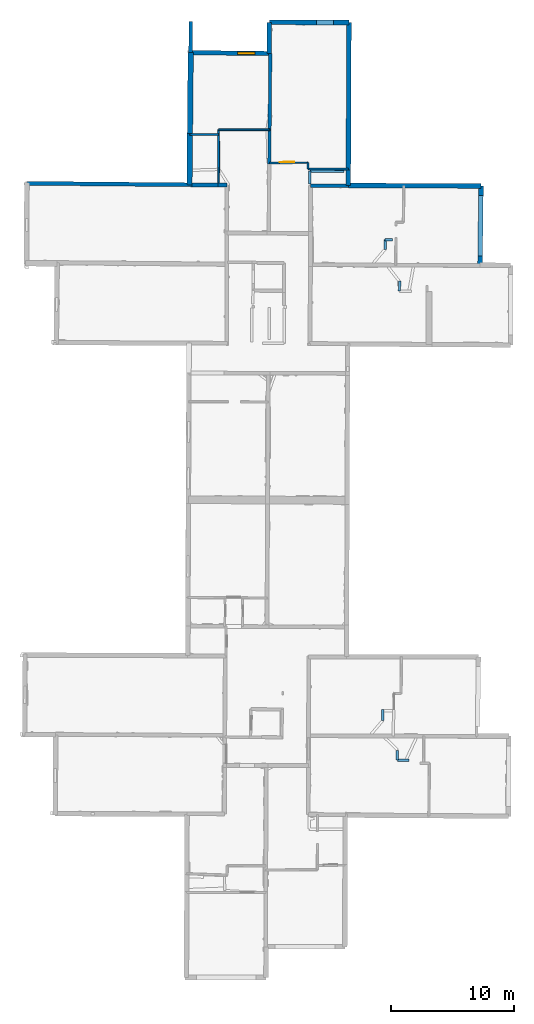
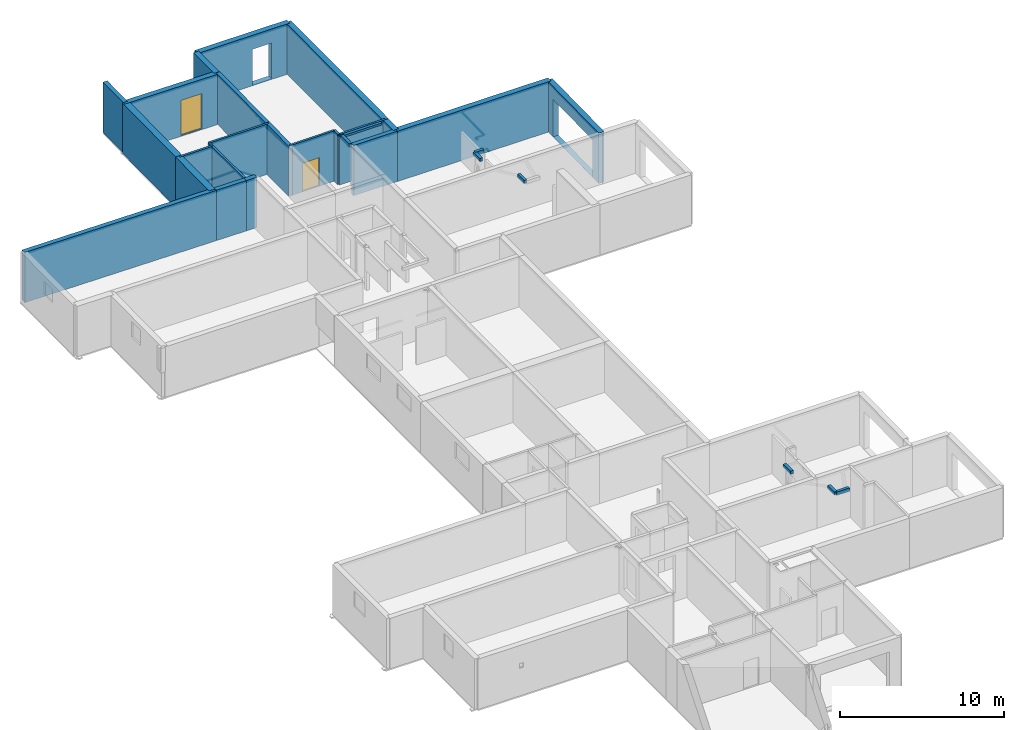
# One storey, part 7 of 12: 30 walls, 1 door, 1 window, 4 openings.
"""IFC2X3 building model written with IfcOpenShell, lengths in metres."""

from ifc_helpers import new_model, entity, si_unit, converted_unit, derived_unit, direction, frame, frame_2d, origin, origin_2d_with_axis, place, context, subcontext, project, spatial, polyline, rectangle, outline, extrude, source, transform, mapped, material, layer, layer_set, layer_usage, type_object, type_shapes, element, fill, save


model = new_model("IFC2X3")

# Units and contexts
model_context = context("Model", 3, precision=1e-05, world=origin(), true_north=direction((0.0, 1.0)))
body_context = subcontext(model_context, "Body", "Model", "MODEL_VIEW")
ifc_project = project(units=[si_unit("LENGTHUNIT", "METRE"), si_unit("AREAUNIT", "SQUARE_METRE"), si_unit("VOLUMEUNIT", "CUBIC_METRE"), converted_unit("PLANEANGLEUNIT", "DEGREE", entity("IfcRatioMeasure", 0.0174532925199433), si_unit("PLANEANGLEUNIT", "RADIAN"), dimensions=[0, 0, 0, 0, 0, 0, 0]), si_unit("MASSUNIT", "GRAM", prefix="KILO"), derived_unit("MASSDENSITYUNIT", [(si_unit("MASSUNIT", "GRAM", prefix="KILO"), 1), (si_unit("LENGTHUNIT", "METRE"), -3)]), derived_unit("MOMENTOFINERTIAUNIT", [(si_unit("LENGTHUNIT", "METRE"), 4)]), si_unit("TIMEUNIT", "SECOND"), si_unit("FREQUENCYUNIT", "HERTZ"), si_unit("THERMODYNAMICTEMPERATUREUNIT", "DEGREE_CELSIUS"), derived_unit("THERMALTRANSMITTANCEUNIT", [(si_unit("MASSUNIT", "GRAM", prefix="KILO"), 1), (si_unit("THERMODYNAMICTEMPERATUREUNIT", "KELVIN"), -1), (si_unit("TIMEUNIT", "SECOND"), -3)]), derived_unit("VOLUMETRICFLOWRATEUNIT", [(si_unit("LENGTHUNIT", "METRE"), 3), (si_unit("TIMEUNIT", "SECOND"), -1)]), si_unit("ELECTRICCURRENTUNIT", "AMPERE"), si_unit("ELECTRICVOLTAGEUNIT", "VOLT"), si_unit("POWERUNIT", "WATT"), si_unit("FORCEUNIT", "NEWTON", prefix="KILO"), si_unit("ILLUMINANCEUNIT", "LUX"), si_unit("LUMINOUSFLUXUNIT", "LUMEN"), si_unit("LUMINOUSINTENSITYUNIT", "CANDELA"), derived_unit("USERDEFINED", [(si_unit("MASSUNIT", "GRAM", prefix="KILO"), -1), (si_unit("LENGTHUNIT", "METRE"), -2), (si_unit("TIMEUNIT", "SECOND"), 3), (si_unit("LUMINOUSFLUXUNIT", "LUMEN"), 1)]), derived_unit("LINEARVELOCITYUNIT", [(si_unit("LENGTHUNIT", "METRE"), 1), (si_unit("TIMEUNIT", "SECOND"), -1)]), si_unit("PRESSUREUNIT", "PASCAL"), derived_unit("USERDEFINED", [(si_unit("LENGTHUNIT", "METRE"), -2), (si_unit("MASSUNIT", "GRAM", prefix="KILO"), 1), (si_unit("TIMEUNIT", "SECOND"), -2)]), derived_unit("LINEARFORCEUNIT", [(si_unit("MASSUNIT", "GRAM", prefix="KILO"), 1), (si_unit("LENGTHUNIT", "METRE"), 1), (si_unit("TIMEUNIT", "SECOND"), -2), (si_unit("LENGTHUNIT", "METRE"), -1)]), derived_unit("PLANARFORCEUNIT", [(si_unit("MASSUNIT", "GRAM", prefix="KILO"), 1), (si_unit("LENGTHUNIT", "METRE"), 1), (si_unit("TIMEUNIT", "SECOND"), -2), (si_unit("LENGTHUNIT", "METRE"), -2)])], contexts=[model_context])

# Site, building, storey
placement_1 = place(None, origin())
site = spatial("IfcSite", under=ifc_project, at=placement_1, CompositionType="ELEMENT")
building = spatial("IfcBuilding", under=site, at=placement_1, CompositionType="ELEMENT")
storey_placement = place(placement_1, frame((0.0, 0.0, -1.46125340461731)))
storey = spatial("IfcBuildingStorey", under=building, at=storey_placement, Name="Level 1", CompositionType="ELEMENT", Elevation=-1.46125340461731)

# Walls
ifc_material_1 = material(Name="Default wall")
ifc_layer_1 = layer(ifc_material_1, 0.2)
ifc_layer_set_1 = layer_set([ifc_layer_1], Name="wall_thickness_0.2000")
ifc_layer_usage_1 = layer_usage(ifc_layer_set_1, "AXIS2", "POSITIVE", -0.1)
wall_type_1 = type_object("IfcWallType", Name="wall_thickness_0.2000", PredefinedType="STANDARD", material=ifc_layer_set_1)
placement_2 = place(placement_1, frame((0.0, 0.0, 2.04199981689453)))
wall_1_placement = place(placement_2, frame((16.985654750279, 56.2841287102002, 0.0), z_axis=(0.0, 0.0, 1.0), x_axis=(-0.0121053675292817, -0.99992672735405, 0.0)))
element("IfcWallStandardCase", 1, at=wall_1_placement, inside=storey, type_object=wall_type_1, material=ifc_layer_usage_1, Name="Wall:504", ObjectType="Wall", context=body_context, shape_type="SweptSolid", body=[
    extrude(outline(polyline([(0.816172321416088, -0.1), (0.816172321416088, 0.1), (0.0, 0.1), (0.0, -0.1), (0.816172321416088, -0.1)])), origin(), (0.0, 0.0, 1.0), 0.238732957839966),
])
placement_3 = place(placement_1, frame((0.0, 0.0, 2.04199981689453)))
wall_2_placement = place(placement_3, frame((16.8142261509141, 17.420475651586, 0.0), z_axis=(0.0, 0.0, 1.0), x_axis=(0.999991195936231, -0.00419619470792084, 0.0)))
element("IfcWallStandardCase", 2, at=wall_2_placement, inside=storey, type_object=wall_type_1, material=ifc_layer_usage_1, Name="Wall:505", ObjectType="Wall", context=body_context, shape_type="SweptSolid", body=[
    extrude(outline(polyline([(0.923630263047391, -0.1), (0.923630263047391, 0.1), (0.0, 0.1), (0.0, -0.1), (0.923630263047391, -0.1)])), origin(), (0.0, 0.0, 1.0), 0.238732957839966),
])
placement_4 = place(placement_1, frame((0.0, 0.0, 2.04199981689453)))
wall_3_placement = place(placement_4, frame((9.69834329614424, 64.1648029776618, 0.0), z_axis=(0.0, 0.0, 1.0), x_axis=(0.00701452156473721, 0.999975397940978, 0.0)))
element("IfcWallStandardCase", 3, at=wall_3_placement, inside=storey, type_object=wall_type_1, material=ifc_layer_usage_1, Name="Wall:583", ObjectType="Wall", context=body_context, shape_type="SweptSolid", body=[
    extrude(outline(polyline([(1.04156767793214, -0.1), (1.04156767793214, 0.1), (0.0, 0.1), (0.0, -0.1), (1.04156767793214, -0.1)])), origin(), (0.0, 0.0, 1.0), 0.238732957839966),
])
placement_5 = place(placement_1, frame((0.0, 0.0, 2.04199981689453)))
wall_4_placement = place(placement_5, frame((16.808737898838, 18.2231718518837, 0.0), z_axis=(0.0, 0.0, 1.0), x_axis=(0.00683613511522928, -0.999976633355343, 0.0)))
element("IfcWallStandardCase", 4, at=wall_4_placement, inside=storey, type_object=wall_type_1, material=ifc_layer_usage_1, Name="Wall:611", ObjectType="Wall", context=body_context, shape_type="SweptSolid", body=[
    extrude(outline(polyline([(0.80271116999675, -0.1), (0.80271116999675, 0.1), (0.0, 0.1), (0.0, -0.1), (0.80271116999675, -0.1)])), origin(), (0.0, 0.0, 1.0), 0.238732957839966),
])
placement_6 = place(placement_1, frame((0.0, 0.0, 2.12299990653992)))
wall_5_placement = place(placement_6, frame((9.70564890685187, 65.2063443058556, 0.0), z_axis=(0.0, 0.0, 1.0), x_axis=(0.999987730149412, -0.00495374107381496, 0.0)))
element("IfcWallStandardCase", 5, at=wall_5_placement, inside=storey, type_object=wall_type_1, material=ifc_layer_usage_1, Name="Wall:655", ObjectType="Wall", context=body_context, shape_type="SweptSolid", body=[
    extrude(outline(polyline([(2.75836895830037, -0.1), (2.75836895830037, 0.1), (0.0, 0.1), (0.0, -0.1), (2.75836895830037, -0.1)])), origin(), (0.0, 0.0, 1.0), 0.15773286819458),
])
placement_7 = place(placement_1, frame((0.0, 0.0, 2.04199981689453)))
wall_6_placement = place(placement_7, frame((15.8125416978923, 59.6423287890546, 0.0), z_axis=(0.0, 0.0, 1.0), x_axis=(0.999998553805146, 0.00170070209538718, 0.0)))
element("IfcWallStandardCase", 6, at=wall_6_placement, inside=storey, type_object=wall_type_1, material=ifc_layer_usage_1, Name="Wall:676", ObjectType="Wall", context=body_context, shape_type="SweptSolid", body=[
    extrude(outline(polyline([(0.601127540184958, -0.1), (0.601127540184958, 0.1), (0.0, 0.1), (0.0, -0.1), (0.601127540184958, -0.1)])), origin(), (0.0, 0.0, 1.0), 0.238732957839966),
])
placement_8 = place(placement_1, frame((0.0, 0.0, 2.04199981689453)))
wall_7_placement = place(placement_8, frame((15.6015710128268, 21.5458410889888, 0.0), z_axis=(0.0, 0.0, 1.0), x_axis=(0.00358453481528218, -0.999993575534442, 0.0)))
element("IfcWallStandardCase", 7, at=wall_7_placement, inside=storey, type_object=wall_type_1, material=ifc_layer_usage_1, Name="Wall:682", ObjectType="Wall", context=body_context, shape_type="SweptSolid", body=[
    extrude(outline(polyline([(0.895000485617568, -0.1), (0.895000485617568, 0.1), (0.0, 0.1), (0.0, -0.1), (0.895000485617568, -0.1)])), origin(), (0.0, 0.0, 1.0), 0.238732957839966),
])
placement_9 = place(placement_1, frame((0.0, 0.0, 2.04199981689453)))
wall_8_placement = place(placement_9, frame((15.8125424604452, 59.6423196106823, 0.0), z_axis=(0.0, 0.0, 1.0), x_axis=(-0.00121170724026811, -0.999999265882512, 0.0)))
element("IfcWallStandardCase", 8, at=wall_8_placement, inside=storey, type_object=wall_type_1, material=ifc_layer_usage_1, Name="Wall:683", ObjectType="Wall", context=body_context, shape_type="SweptSolid", body=[
    extrude(outline(polyline([(0.805939312357268, -0.1), (0.805939312357268, 0.1), (0.0, 0.1), (0.0, -0.1), (0.805939312357268, -0.1)])), origin(), (0.0, 0.0, 1.0), 0.238732957839966),
])
ifc_layer_2 = layer(ifc_material_1, 0.259999990463257)
ifc_layer_set_2 = layer_set([ifc_layer_2], Name="wall_thickness_0.2600")
ifc_layer_usage_2 = layer_usage(ifc_layer_set_2, "AXIS2", "POSITIVE", -0.129999995231628)
wall_type_2 = type_object("IfcWallType", Name="wall_thickness_0.2600", PredefinedType="STANDARD", material=ifc_layer_set_2)
wall_9_placement = place(storey_placement, frame((6.49996284418517, 74.7443415367657, 0.0), z_axis=(0.0, 0.0, 1.0), x_axis=(-0.00925311069373297, -0.999957189054856, 0.0)))
element("IfcWallStandardCase", 9, at=wall_9_placement, inside=storey, type_object=wall_type_2, material=ifc_layer_usage_2, Name="Wall:622", ObjectType="Wall", context=body_context, shape_type="SweptSolid", body=[
    extrude(outline(polyline([(6.10981204290243, -0.129999995231628), (6.10981204290243, 0.129999995231628), (0.0, 0.129999995231628), (0.0, -0.129999995231628), (6.10981204290243, -0.129999995231628)])), origin(), (0.0, 0.0, 1.0), 3.74198617935181),
])
wall_10_placement = place(storey_placement, frame((6.44342807703429, 68.6347910606915, 0.0), z_axis=(0.0, 0.0, 1.0), x_axis=(-0.00925297889568867, -0.999957190274442, 0.0)))
element("IfcWallStandardCase", 10, at=wall_10_placement, inside=storey, type_object=wall_type_2, material=ifc_layer_usage_2, Name="Wall:623", ObjectType="Wall", context=body_context, shape_type="SweptSolid", body=[
    extrude(outline(polyline([(2.84840379973651, -0.129999995231628), (2.84840379973651, 0.129999995231628), (0.0, 0.129999995231628), (0.0, -0.129999995231628), (2.84840379973651, -0.129999995231628)])), origin(), (0.0, 0.0, 1.0), 3.74198617935181),
])
ifc_layer_3 = layer(ifc_material_1, 0.379999995231628)
ifc_layer_set_3 = layer_set([ifc_layer_3], Name="wall_thickness_0.3800")
ifc_layer_usage_3 = layer_usage(ifc_layer_set_3, "AXIS2", "POSITIVE", -0.189999997615814)
wall_type_3 = type_object("IfcWallType", Name="wall_thickness_0.3800", PredefinedType="STANDARD", material=ifc_layer_set_3)
wall_11_placement = place(storey_placement, frame((12.8271769752851, 64.0465283454255, 0.0), z_axis=(0.0, 0.0, 1.0), x_axis=(0.999990247252892, -0.0044164917185579, 0.0)))
element("IfcWallStandardCase", 11, at=wall_11_placement, inside=storey, type_object=wall_type_3, material=ifc_layer_usage_3, Name="Wall:577", ObjectType="Wall", context=body_context, shape_type="SweptSolid", body=[
    extrude(outline(polyline([(10.7656460712837, -0.189999997615814), (10.7656460712837, 0.189999997615814), (0.0, 0.189999997615814), (0.0, -0.189999997615814), (10.7656460712837, -0.189999997615814)])), origin(), (0.0, 0.0, 1.0), 3.74198617935181),
])

# Wall, opening
wall_12_placement = place(storey_placement, frame((6.42383307155813, 77.275378400751, 0.0), z_axis=(0.0, 0.0, 1.0), x_axis=(0.999996892159808, -0.00249312469098488, 0.0)))
wall_12 = element("IfcWallStandardCase", 12, at=wall_12_placement, inside=storey, type_object=wall_type_3, material=ifc_layer_usage_3, Name="Wall:607", ObjectType="Wall", context=body_context, shape_type="SweptSolid", body=[
    extrude(outline(polyline([(6.45696644020566, -0.189999997615814), (6.45696644020566, 0.189999997615814), (0.0, 0.189999997615814), (0.0, -0.189999997615814), (6.45696644020566, -0.189999997615814)])), origin(), (0.0, 0.0, 1.0), 3.74198617935181),
])
opening_1_placement = place(wall_12_placement, frame((3.83814585930286, -0.189999997615814, 0.0252540111541748)))
element("IfcOpeningElement", 13, at=opening_1_placement, cuts=wall_12, Name="Opening : 1345 x 2675 : 420", ObjectType="Opening", context=body_context, shape_type="SweptSolid", body=[
    extrude(rectangle(XDim=1.345, YDim=2.675, at=frame_2d((1.3375, 0.6725), x_axis=(0.0, 1.0))), frame((0.0, 0.0, 0.0), z_axis=(0.0, 1.0, 0.0), x_axis=(0.0, 0.0, 1.0)), (0.0, 0.0, 1.0), 0.379999995231628),
])

# Walls
wall_13_placement = place(storey_placement, frame((12.8807794590913, 77.2592776062909, 0.0), z_axis=(0.0, 0.0, 1.0), x_axis=(-0.00405701268422261, -0.999991770290176, 0.0)))
element("IfcWallStandardCase", 14, at=wall_13_placement, inside=storey, type_object=wall_type_3, material=ifc_layer_usage_3, Name="Wall:645", ObjectType="Wall", context=body_context, shape_type="SweptSolid", body=[
    extrude(outline(polyline([(11.9640266831242, -0.189999997615814), (11.9640266831242, 0.189999997615814), (0.0, 0.189999997615814), (0.0, -0.189999997615814), (11.9640266831242, -0.189999997615814)])), origin(), (0.0, 0.0, 1.0), 3.74198617935181),
])
wall_14_placement = place(storey_placement, frame((12.8322412510835, 65.2953493836346, 0.0), z_axis=(0.0, 0.0, 1.0), x_axis=(-0.00405735191516471, -0.999991768913843, 0.0)))
element("IfcWallStandardCase", 15, at=wall_14_placement, inside=storey, type_object=wall_type_3, material=ifc_layer_usage_3, Name="Wall:646", ObjectType="Wall", context=body_context, shape_type="SweptSolid", body=[
    extrude(outline(polyline([(1.24881246414158, -0.189999997615814), (1.24881246414158, 0.189999997615814), (0.0, 0.189999997615814), (0.0, -0.189999997615814), (1.24881246414158, -0.189999997615814)])), origin(), (0.0, 0.0, 1.0), 3.74198617935181),
])

# Wall, opening
wall_15_placement = place(storey_placement, frame((23.5927183697657, 63.9989821402971, 0.0), z_axis=(0.0, 0.0, 1.0), x_axis=(-0.0125521284656519, -0.999921218932263, 0.0)))
wall_15 = element("IfcWallStandardCase", 16, at=wall_15_placement, inside=storey, type_object=wall_type_3, material=ifc_layer_usage_3, Name="Wall:647", ObjectType="Wall", context=body_context, shape_type="SweptSolid", body=[
    extrude(outline(polyline([(6.45410266886321, -0.189999997615814), (6.45410266886321, 0.189999997615814), (0.0, 0.189999997615814), (0.0, -0.189999997615814), (6.45410266886321, -0.189999997615814)])), origin(), (0.0, 0.0, 1.0), 3.74198617935181),
])
opening_2_placement = place(wall_15_placement, frame((0.781940975481089, -0.189999997615814, 0.00525403022766113)))
element("IfcOpeningElement", 17, at=opening_2_placement, cuts=wall_15, Name="Opening : 4910 x 2770 : 424", ObjectType="Opening", context=body_context, shape_type="SweptSolid", body=[
    extrude(rectangle(XDim=4.91, YDim=2.77, at=frame_2d((1.385, 2.455), x_axis=(0.0, 1.0))), frame((0.0, 0.0, 0.0), z_axis=(0.0, 1.0, 0.0), x_axis=(0.0, 0.0, 1.0)), (0.0, 0.0, 1.0), 0.379999995231628),
])

# Wall
ifc_layer_4 = layer(ifc_material_1, 0.370000004768372)
ifc_layer_set_4 = layer_set([ifc_layer_4], Name="wall_thickness_0.3700")
ifc_layer_usage_4 = layer_usage(ifc_layer_set_4, "AXIS2", "POSITIVE", -0.185000002384186)
wall_type_4 = type_object("IfcWallType", Name="wall_thickness_0.3700", PredefinedType="STANDARD", material=ifc_layer_set_4)
wall_16_placement = place(storey_placement, frame((6.4238338680527, 77.2753813323718, 0.0), z_axis=(0.0, 0.0, 1.0), x_axis=(-0.00458695900539811, -0.999989479848205, 0.0)))
element("IfcWallStandardCase", 18, at=wall_16_placement, inside=storey, type_object=wall_type_4, material=ifc_layer_usage_4, Name="Wall:517", ObjectType="Wall", context=body_context, shape_type="SweptSolid", body=[
    extrude(outline(polyline([(2.53005591344726, -0.185000002384186), (2.53005591344726, 0.185000002384186), (0.0, 0.185000002384186), (0.0, -0.185000002384186), (2.53005591344726, -0.185000002384186)])), origin(), (0.0, 0.0, 1.0), 3.74198617935181),
])

# Wall, opening, window
ifc_layer_5 = layer(ifc_material_1, 0.360000014305115)
ifc_layer_set_5 = layer_set([ifc_layer_5], Name="wall_thickness_0.3600")
ifc_layer_usage_5 = layer_usage(ifc_layer_set_5, "AXIS2", "POSITIVE", -0.180000007152557)
wall_type_5 = type_object("IfcWallType", Name="wall_thickness_0.3600", PredefinedType="STANDARD", material=ifc_layer_set_5)
wall_17_placement = place(storey_placement, frame((-0.0998049657116847, 74.8212939685536, 0.0), z_axis=(0.0, 0.0, 1.0), x_axis=(0.999932034790129, -0.0116587220771741, 0.0)))
wall_17 = element("IfcWallStandardCase", 19, at=wall_17_placement, inside=storey, type_object=wall_type_5, material=ifc_layer_usage_5, Name="Wall:572", ObjectType="Wall", context=body_context, shape_type="SweptSolid", body=[
    extrude(outline(polyline([(6.60021507784659, -0.180000007152557), (6.60021507784659, 0.180000007152557), (0.0, 0.180000007152557), (0.0, -0.180000007152557), (6.60021507784659, -0.180000007152557)])), origin(), (0.0, 0.0, 1.0), 3.74198617935181),
])
opening_3_placement = place(wall_17_placement, frame((3.91921047289283, -0.180000007152557, 0.0702539682388306)))
opening_3 = element("IfcOpeningElement", 20, at=opening_3_placement, cuts=wall_17, Name="Opening : 1440 x 2610 : 413", ObjectType="Opening", context=body_context, shape_type="SweptSolid", body=[
    extrude(rectangle(XDim=1.44, YDim=2.61, at=frame_2d((1.305, 0.72), x_axis=(0.0, 1.0))), frame((0.0, 0.0, 0.0), z_axis=(0.0, 1.0, 0.0), x_axis=(0.0, 0.0, 1.0)), (0.0, 0.0, 1.0), 0.360000014305115),
])
ifc_material_2 = material(Name="Window Default")
window_style = type_object("IfcWindowStyle", Name="Window : 1440 x 2610mm", ConstructionType="NOTDEFINED", OperationType="NOTDEFINED", ParameterTakesPrecedence=False, Sizeable=False, material=ifc_material_2)
shared_shape_1 = source(origin(), body_context, "Body", "SweptSolid", [
    extrude(rectangle(XDim=0.180000007152557, YDim=1.44, at=origin_2d_with_axis()), frame((0.72, 0.180000007152557, 0.0), z_axis=(0.0, 0.0, 1.0), x_axis=(0.0, 1.0, 0.0)), (0.0, 0.0, 1.0), 2.61),
])
type_shapes(window_style, [shared_shape_1])
window_placement = place(opening_3_placement, origin())
window = element("IfcWindow", 21, at=window_placement, inside=storey, type_object=window_style, Name="Window : 1440 x 2610mm : 229", ObjectType="Window : 1440 x 2610mm", OverallHeight=2.61, OverallWidth=1.44, context=body_context, shape_type="MappedRepresentation", body=[
    mapped(shared_shape_1, transform((0.0, 0.0, 0.0), scale=1.0)),
])
fill(opening_3, window)

# Walls
ifc_layer_6 = layer(ifc_material_1, 0.150000005960464)
ifc_layer_set_6 = layer_set([ifc_layer_6], Name="wall_thickness_0.1500")
ifc_layer_usage_6 = layer_usage(ifc_layer_set_6, "AXIS2", "POSITIVE", -0.0750000029802322)
wall_type_6 = type_object("IfcWallType", Name="wall_thickness_0.1500", PredefinedType="STANDARD", material=ifc_layer_set_6)
wall_18_placement = place(storey_placement, frame((9.57041502275993, 65.3777647023615, 0.0), z_axis=(0.0, 0.0, 1.0), x_axis=(0.999997416086211, -0.00227328416665952, 0.0)))
element("IfcWallStandardCase", 22, at=wall_18_placement, inside=storey, type_object=wall_type_6, material=ifc_layer_usage_6, Name="Wall:536", ObjectType="Wall", context=body_context, shape_type="SweptSolid", body=[
    extrude(outline(polyline([(3.26214012006784, -0.0750000029802322), (3.26214012006784, 0.0750000029802322), (0.0, 0.0750000029802322), (0.0, -0.0750000029802322), (3.26214012006784, -0.0750000029802322)])), origin(), (0.0, 0.0, 1.0), 3.74198617935181),
])
wall_19_placement = place(storey_placement, frame((2.29924030453117, 68.5605285626273, 0.0), z_axis=(0.0, 0.0, 1.0), x_axis=(0.99999998437719, -0.000176764305854658, 0.0)))
element("IfcWallStandardCase", 23, at=wall_19_placement, inside=storey, type_object=wall_type_6, material=ifc_layer_usage_6, Name="Wall:568", ObjectType="Wall", context=body_context, shape_type="SweptSolid", body=[
    extrude(outline(polyline([(4.14349419391393, -0.0750000029802322), (4.14349419391393, 0.0750000029802322), (0.0, 0.0750000029802322), (0.0, -0.0750000029802322), (4.14349419391393, -0.0750000029802322)])), origin(), (0.0, 0.0, 1.0), 3.74198617935181),
])

# Wall, opening, door
wall_20_placement = place(storey_placement, frame((6.41776554010795, 65.8614954213008, 0.0), z_axis=(0.0, 0.0, 1.0), x_axis=(0.999951938311909, 0.00980413516103042, 0.0)))
wall_20 = element("IfcWallStandardCase", 24, at=wall_20_placement, inside=storey, type_object=wall_type_6, material=ifc_layer_usage_6, Name="Wall:596", ObjectType="Wall", context=body_context, shape_type="SweptSolid", body=[
    extrude(outline(polyline([(3.15396876188173, -0.0750000029802322), (3.15396876188173, 0.0750000029802322), (0.0, 0.0750000029802322), (0.0, -0.0750000029802322), (3.15396876188173, -0.0750000029802322)])), origin(), (0.0, 0.0, 1.0), 3.74198617935181),
])
opening_4_placement = place(wall_20_placement, frame((0.841534071344861, -0.0750000029802322, 0.00525403022766113)))
opening_4 = element("IfcOpeningElement", 25, at=opening_4_placement, cuts=wall_20, Name="Opening : 1195 x 2120 : 418", ObjectType="Opening", context=body_context, shape_type="SweptSolid", body=[
    extrude(rectangle(XDim=1.195, YDim=2.12, at=frame_2d((1.06, 0.5975), x_axis=(0.0, 1.0))), frame((0.0, 0.0, 0.0), z_axis=(0.0, 1.0, 0.0), x_axis=(0.0, 0.0, 1.0)), (0.0, 0.0, 1.0), 0.150000005960464),
])
ifc_material_3 = material(Name="Door Panel")
door_style = type_object("IfcDoorStyle", Name="Door : 1195 x 2120mm", ConstructionType="NOTDEFINED", OperationType="SINGLE_SWING_RIGHT", ParameterTakesPrecedence=False, Sizeable=False, material=ifc_material_3)
shared_shape_2 = source(origin(), body_context, "Body", "SweptSolid", [
    extrude(rectangle(XDim=0.0375000014901161, YDim=1.195, at=origin_2d_with_axis()), frame((0.5975, 0.131250005215406, 0.0), z_axis=(0.0, 0.0, 1.0), x_axis=(0.0, 1.0, 0.0)), (0.0, 0.0, 1.0), 2.12),
])
type_shapes(door_style, [shared_shape_2])
door_placement = place(opening_4_placement, origin())
door = element("IfcDoor", 26, at=door_placement, inside=storey, type_object=door_style, Name="Door : 1195 x 2120mm : 78", ObjectType="Door : 1195 x 2120mm", OverallHeight=2.12, OverallWidth=1.195, context=body_context, shape_type="MappedRepresentation", body=[
    mapped(shared_shape_2, transform((0.0, 0.0, 0.0), scale=1.0)),
])
fill(opening_4, door)

# Walls
wall_21_placement = place(storey_placement, frame((-0.0197053436772811, 68.1802567292397, 0.0), z_axis=(0.0, 0.0, 1.0), x_axis=(0.999998943990349, -0.00145327842746965, 0.0)))
element("IfcWallStandardCase", 27, at=wall_21_placement, inside=storey, type_object=wall_type_6, material=ifc_layer_usage_6, Name="Wall:600", ObjectType="Wall", context=body_context, shape_type="SweptSolid", body=[
    extrude(outline(polyline([(2.32040352287065, -0.0750000029802322), (2.32040352287065, 0.0750000029802322), (0.0, 0.0750000029802322), (0.0, -0.0750000029802322), (2.32040352287065, -0.0750000029802322)])), origin(), (0.0, 0.0, 1.0), 3.74198617935181),
])
wall_22_placement = place(storey_placement, frame((2.29924048167827, 68.560518568154, 0.0), z_axis=(0.0, 0.0, 1.0), x_axis=(0.00379329671372896, -0.99999280542414, 0.0)))
element("IfcWallStandardCase", 28, at=wall_22_placement, inside=storey, type_object=wall_type_6, material=ifc_layer_usage_6, Name="Wall:673", ObjectType="Wall", context=body_context, shape_type="SweptSolid", body=[
    extrude(outline(polyline([(4.48201924573919, -0.0750000029802322), (4.48201924573919, 0.0750000029802322), (0.0, 0.0750000029802322), (0.0, -0.0750000029802322), (4.48201924573919, -0.0750000029802322)])), origin(), (0.0, 0.0, 1.0), 3.74198617935181),
])
ifc_layer_7 = layer(ifc_material_1, 0.319999992847443)
ifc_layer_set_7 = layer_set([ifc_layer_7], Name="wall_thickness_0.3200")
ifc_layer_usage_7 = layer_usage(ifc_layer_set_7, "AXIS2", "POSITIVE", -0.159999996423721)
wall_type_7 = type_object("IfcWallType", Name="wall_thickness_0.3200", PredefinedType="STANDARD", material=ifc_layer_set_7)
wall_23_placement = place(storey_placement, frame((-13.2510322111303, 64.2190831365429, 0.0), z_axis=(0.0, 0.0, 1.0), x_axis=(0.99995924545075, -0.00902814696197252, 0.0)))
element("IfcWallStandardCase", 29, at=wall_23_placement, inside=storey, type_object=wall_type_7, material=ifc_layer_usage_7, Name="Wall:569", ObjectType="Wall", context=body_context, shape_type="SweptSolid", body=[
    extrude(outline(polyline([(13.4129130274528, -0.159999996423721), (13.4129130274528, 0.159999996423721), (0.0, 0.159999996423721), (0.0, -0.159999996423721), (13.4129130274528, -0.159999996423721)])), origin(), (0.0, 0.0, 1.0), 3.74198617935181),
])
wall_24_placement = place(storey_placement, frame((0.161334179097929, 64.0979893865429, 0.0), z_axis=(0.0, 0.0, 1.0), x_axis=(0.999959256864479, -0.00902688268661936, 0.0)))
element("IfcWallStandardCase", 30, at=wall_24_placement, inside=storey, type_object=wall_type_7, material=ifc_layer_usage_7, Name="Wall:570", ObjectType="Wall", context=body_context, shape_type="SweptSolid", body=[
    extrude(outline(polyline([(2.08000265354484, -0.159999996423721), (2.08000265354484, 0.159999996423721), (0.0, 0.159999996423721), (0.0, -0.159999996423721), (2.08000265354484, -0.159999996423721)])), origin(), (0.0, 0.0, 1.0), 3.74198617935181),
])
wall_25_placement = place(storey_placement, frame((2.24125208681277, 64.0792134466015, 0.0), z_axis=(0.0, 0.0, 1.0), x_axis=(0.999959229708781, -0.00902989037707823, 0.0)))
element("IfcWallStandardCase", 31, at=wall_25_placement, inside=storey, type_object=wall_type_7, material=ifc_layer_usage_7, Name="Wall:571", ObjectType="Wall", context=body_context, shape_type="SweptSolid", body=[
    extrude(outline(polyline([(0.730842346246356, -0.159999996423721), (0.730842346246356, 0.159999996423721), (0.0, 0.159999996423721), (0.0, -0.159999996423721), (0.730842346246356, -0.159999996423721)])), origin(), (0.0, 0.0, 1.0), 3.74198617935181),
])
ifc_layer_8 = layer(ifc_material_1, 0.300000011920929)
ifc_layer_set_8 = layer_set([ifc_layer_8], Name="wall_thickness_0.3000")
ifc_layer_usage_8 = layer_usage(ifc_layer_set_8, "AXIS2", "POSITIVE", -0.150000005960464)
wall_type_8 = type_object("IfcWallType", Name="wall_thickness_0.3000", PredefinedType="STANDARD", material=ifc_layer_set_8)
wall_26_placement = place(storey_placement, frame((9.76334054837803, 64.0307336630822, 0.0), z_axis=(0.0, 0.0, 1.0), x_axis=(0.999993694999425, -0.00355105074553032, 0.0)))
element("IfcWallStandardCase", 32, at=wall_26_placement, inside=storey, type_object=wall_type_8, material=ifc_layer_usage_8, Name="Wall:617", ObjectType="Wall", context=body_context, shape_type="SweptSolid", body=[
    extrude(outline(polyline([(3.06374574208956, -0.150000005960464), (3.06374574208956, 0.150000005960464), (0.0, 0.150000005960464), (0.0, -0.150000005960464), (3.06374574208956, -0.150000005960464)])), origin(), (0.0, 0.0, 1.0), 3.74198617935181),
])
wall_27_placement = place(storey_placement, frame((0.0555424385431177, 77.3374563418405, 0.0), z_axis=(0.0, 0.0, 1.0), x_axis=(-0.0111428649234545, -0.999937916353459, 0.0)))
element("IfcWallStandardCase", 33, at=wall_27_placement, inside=storey, type_object=wall_type_8, material=ifc_layer_usage_8, Name="Wall:661", ObjectType="Wall", context=body_context, shape_type="SweptSolid", body=[
    extrude(outline(polyline([(2.5177878442123, -0.150000005960464), (2.5177878442123, 0.150000005960464), (0.0, 0.150000005960464), (0.0, -0.150000005960464), (2.5177878442123, -0.150000005960464)])), origin(), (0.0, 0.0, 1.0), 3.74198617935181),
])
ifc_layer_9 = layer(ifc_material_1, 0.163442090153694)
ifc_layer_set_9 = layer_set([ifc_layer_9], Name="wall_thickness_0.1634")
ifc_layer_usage_9 = layer_usage(ifc_layer_set_9, "AXIS2", "POSITIVE", -0.0817210450768471)
wall_type_9 = type_object("IfcWallType", Name="wall_thickness_0.1634", PredefinedType="STANDARD", material=ifc_layer_set_9)
wall_28_placement = place(storey_placement, frame((9.57158327332234, 65.8924064636162, 0.0), z_axis=(0.0, 0.0, 1.0), x_axis=(-0.00226631987844883, -0.999997431893807, 0.0)))
element("IfcWallStandardCase", 34, at=wall_28_placement, inside=storey, type_object=wall_type_9, material=ifc_layer_usage_9, Name="Wall:535", ObjectType="Wall", context=body_context, shape_type="SweptSolid", body=[
    extrude(outline(polyline([(0.51464212976111, -0.0817210450768471), (0.51464212976111, 0.0817210450768471), (0.0, 0.0817210450768471), (0.0, -0.0817210450768471), (0.51464212976111, -0.0817210450768471)])), origin(), (0.0, 0.0, 1.0), 3.74198617935181),
])
ifc_layer_10 = layer(ifc_material_1, 0.439999997615814)
ifc_layer_set_10 = layer_set([ifc_layer_10], Name="wall_thickness_0.4400")
ifc_layer_usage_10 = layer_usage(ifc_layer_set_10, "AXIS2", "POSITIVE", -0.219999998807907)
wall_type_10 = type_object("IfcWallType", Name="wall_thickness_0.4400", PredefinedType="STANDARD", material=ifc_layer_set_10)
wall_29_placement = place(storey_placement, frame((0.0436770423626149, 74.8196355044566, 0.0), z_axis=(0.0, 0.0, 1.0), x_axis=(-0.00954593287988729, -0.999954436544712, 0.0)))
element("IfcWallStandardCase", 35, at=wall_29_placement, inside=storey, type_object=wall_type_10, material=ifc_layer_usage_10, Name="Wall:537", ObjectType="Wall", context=body_context, shape_type="SweptSolid", body=[
    extrude(outline(polyline([(6.56468357011554, -0.219999998807907), (6.56468357011554, 0.219999998807907), (0.0, 0.219999998807907), (0.0, -0.219999998807907), (6.56468357011554, -0.219999998807907)])), origin(), (0.0, 0.0, 1.0), 3.74198617935181),
])
wall_30_placement = place(storey_placement, frame((-0.0189889863754069, 68.2552510440074, 0.0), z_axis=(0.0, 0.0, 1.0), x_axis=(-0.00954593683459385, -0.999954436506959, 0.0)))
element("IfcWallStandardCase", 36, at=wall_30_placement, inside=storey, type_object=wall_type_10, material=ifc_layer_usage_10, Name="Wall:538", ObjectType="Wall", context=body_context, shape_type="SweptSolid", body=[
    extrude(outline(polyline([(4.15546277489923, -0.219999998807907), (4.15546277489923, 0.219999998807907), (0.0, 0.219999998807907), (0.0, -0.219999998807907), (4.15546277489923, -0.219999998807907)])), origin(), (0.0, 0.0, 1.0), 3.74198617935181),
])

save(model, "model.ifc")
